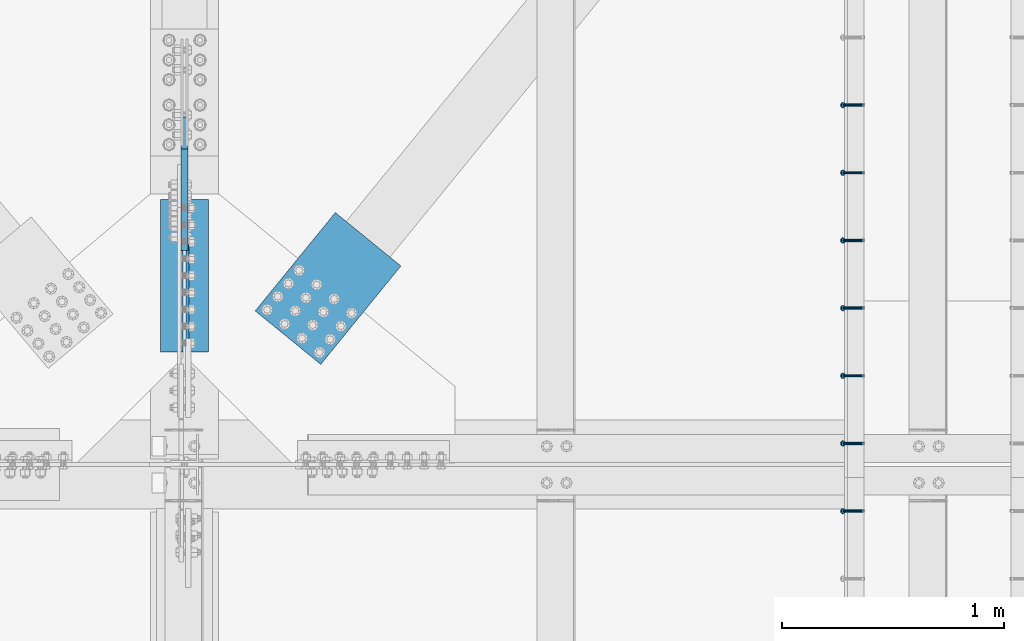
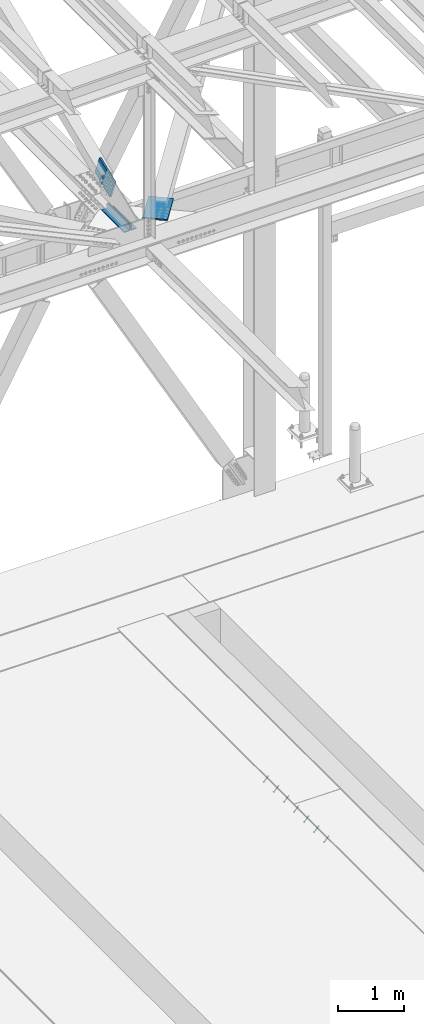
# One storey, part 2493 of 3843: 8 members, 3 beams, 6 elements without a shape of their own.
"""IFC2X3 building model written with IfcOpenShell, lengths in millimetres."""

from ifc_helpers import new_model, si_unit, frame, origin_with_axes, place, context, subcontext, project, spatial, faceted_brep, material, type_object, element, aggregate, save


model = new_model("IFC2X3")

# Units and contexts
model_context = context("Model", 3, precision=1e-05, world=origin_with_axes())
body_context = subcontext(model_context, "Body", "Model", "MODEL_VIEW")
ifc_project = project(units=[si_unit("LENGTHUNIT", "METRE", prefix="MILLI"), si_unit("AREAUNIT", "SQUARE_METRE"), si_unit("VOLUMEUNIT", "CUBIC_METRE"), si_unit("MASSUNIT", "GRAM", prefix="KILO"), si_unit("TIMEUNIT", "SECOND"), si_unit("PLANEANGLEUNIT", "RADIAN"), si_unit("SOLIDANGLEUNIT", "STERADIAN"), si_unit("THERMODYNAMICTEMPERATUREUNIT", "DEGREE_CELSIUS"), si_unit("LUMINOUSINTENSITYUNIT", "LUMEN")], contexts=[model_context])

# Site, building, storey
site_placement = place(None, origin_with_axes())
site = spatial("IfcSite", under=ifc_project, at=site_placement, CompositionType="ELEMENT")
building_placement = place(site_placement, origin_with_axes())
building = spatial("IfcBuilding", under=site, at=building_placement, Name="Undefined", CompositionType="ELEMENT")
storey_placement = place(building_placement, origin_with_axes())
storey = spatial("IfcBuildingStorey", under=building, at=storey_placement, Name="Undefined", CompositionType="ELEMENT", Elevation=0.0)

# Assembly, member
assembly_1_placement = place(storey_placement, origin_with_axes())
assembly_1 = element("IfcElementAssembly", 1, at=assembly_1_placement, inside=storey, Name="EMBED_ANGLE", AssemblyPlace="NOTDEFINED", PredefinedType="RIGID_FRAME")
ifc_material_1 = material(Name="STEEL/A108")
member_type_1 = type_object("IfcMemberType", PredefinedType="NOTDEFINED")
member_1_placement = place(assembly_1_placement, frame((58984.3878603516, 83775.4223186035, 30446.6625), z_axis=(0.0, 1.0, 0.0), x_axis=(-0.707106781186548, 0.0, -0.707106781186548)))
member_1 = element("IfcMember", 2, at=member_1_placement, type_object=member_type_1, material=ifc_material_1, Name="HEADED STUD ANCHOR", context=body_context, shape_type="Brep", body=[
    faceted_brep([(7.27595761418343e-12, -3.18000006675175, 5.5), (0.0, -5.49999999998363, 3.1800000667572), (118.110000000976, -5.49999999999091, 3.1800000667572), (118.110000000983, -3.18000006675175, 5.5), (0.0, -6.3499999046162, 0.0), (118.110000000968, -6.34999990461256, 0.0), (0.0, -5.49999999998363, -3.1800000667572), (118.110000000976, -5.49999999999091, -3.1800000667572), (7.27595761418343e-12, -3.18000006675175, -5.5), (118.110000000983, -3.18000006675175, -5.5), (7.27595761418343e-12, -1.81898940354586e-12, -6.34999990463257), (118.110000000968, -1.81898940354586e-12, -6.34999990463257), (0.0, 3.18000006675175, -5.5), (118.110000000968, 3.18000006674811, -5.5), (7.27595761418343e-12, 5.49999999998363, -3.1800000667572), (118.110000000983, 5.49999999998363, -3.1800000667572), (7.27595761418343e-12, 6.3499999046162, 0.0), (118.110000000976, 6.34999990461256, 0.0), (7.27595761418343e-12, 5.49999999998363, 3.1800000667572), (118.110000000983, 5.49999999998363, 3.1800000667572), (0.0, 3.18000006675175, 5.5), (118.110000000968, 3.18000006674811, 5.5), (7.27595761418343e-12, -1.81898940354586e-12, 6.34999990463257), (118.110000000968, -1.81898940354586e-12, 6.34999990463257), (120.650000000991, -10.9899997710909, 6.34999990463257), (120.650000000998, -6.34000015257152, 10.9899997711182), (120.650000000991, -12.6999998092379, 0.0), (120.650000000991, -10.9899997710909, -6.34999990463257), (120.650000000998, -6.34000015257152, -10.9899997711182), (120.650000000991, -1.81898940354586e-12, -12.6899995803833), (120.650000000991, 6.34000015257152, -10.9899997711182), (120.650000000998, 10.9899997710909, -6.34999990463257), (120.650000000991, 12.6999998092342, 0.0), (120.650000000998, 10.9899997710909, 6.34999990463257), (120.650000000991, 6.34000015257152, 10.9899997711182), (120.650000000991, -1.81898940354586e-12, 12.6899995803833), (127.000000001048, -10.9899997710945, 6.34999990463257), (127.000000001048, -6.34000015257152, 10.9899997711182), (127.000000001048, -12.6999998092342, 0.0), (127.000000001048, -10.9899997710945, -6.34999990463257), (127.000000001048, -6.34000015257152, -10.9899997711182), (127.000000001048, 1.81898940354586e-12, -12.6899995803833), (127.000000001048, 6.34000015256788, -10.9899997711182), (127.000000001048, 10.9899997710909, -6.34999990463257), (127.000000001048, 12.6999998092379, 0.0), (127.000000001048, 10.9899997710909, 6.34999990463257), (127.000000001048, 6.34000015256788, 10.9899997711182), (127.000000001048, 1.81898940354586e-12, 12.6899995803833)], [[[0, 1, 2, 3]], [[1, 4, 5, 2]], [[4, 6, 7, 5]], [[6, 8, 9, 7]], [[8, 10, 11, 9]], [[10, 12, 13, 11]], [[12, 14, 15, 13]], [[14, 16, 17, 15]], [[16, 18, 19, 17]], [[18, 20, 21, 19]], [[20, 22, 23, 21]], [[22, 0, 3, 23]], [[22, 20, 18, 16, 14, 12, 10, 8, 6, 4, 1, 0]], [[3, 2, 24, 25]], [[2, 5, 26, 24]], [[5, 7, 27, 26]], [[7, 9, 28, 27]], [[9, 11, 29, 28]], [[11, 13, 30, 29]], [[13, 15, 31, 30]], [[15, 17, 32, 31]], [[17, 19, 33, 32]], [[19, 21, 34, 33]], [[21, 23, 35, 34]], [[23, 3, 25, 35]], [[25, 24, 36, 37]], [[24, 26, 38, 36]], [[26, 27, 39, 38]], [[27, 28, 40, 39]], [[28, 29, 41, 40]], [[29, 30, 42, 41]], [[30, 31, 43, 42]], [[31, 32, 44, 43]], [[32, 33, 45, 44]], [[33, 34, 46, 45]], [[34, 35, 47, 46]], [[35, 25, 37, 47]], [[38, 39, 40, 41, 42, 43, 44, 45, 46, 47, 37, 36]]]),
])
aggregate(assembly_1, [member_1])

# Assembly, members
assembly_2_placement = place(storey_placement, origin_with_axes())
assembly_2 = element("IfcElementAssembly", 3, at=assembly_2_placement, inside=storey, Name="EMBED_ANGLE", AssemblyPlace="NOTDEFINED", PredefinedType="RIGID_FRAME")
member_2_placement = place(assembly_2_placement, frame((58984.3878603516, 84080.2223186035, 30446.6625), z_axis=(0.0, 1.0, 0.0), x_axis=(-0.707106781186548, 0.0, -0.707106781186548)))
member_2 = element("IfcMember", 4, at=member_2_placement, type_object=member_type_1, material=ifc_material_1, Name="HEADED STUD ANCHOR", context=body_context, shape_type="Brep", body=[
    faceted_brep([(7.27595761418343e-12, -3.18000006675175, 5.5), (0.0, -5.49999999998363, 3.1800000667572), (118.110000000976, -5.49999999999091, 3.1800000667572), (118.110000000983, -3.18000006675175, 5.5), (0.0, -6.3499999046162, 0.0), (118.110000000968, -6.34999990461256, 0.0), (0.0, -5.49999999998363, -3.1800000667572), (118.110000000976, -5.49999999999091, -3.1800000667572), (7.27595761418343e-12, -3.18000006675175, -5.5), (118.110000000983, -3.18000006675175, -5.5), (7.27595761418343e-12, -1.81898940354586e-12, -6.34999990463257), (118.110000000968, -1.81898940354586e-12, -6.34999990463257), (0.0, 3.18000006675175, -5.5), (118.110000000968, 3.18000006674811, -5.5), (7.27595761418343e-12, 5.49999999998363, -3.1800000667572), (118.110000000983, 5.49999999998363, -3.1800000667572), (7.27595761418343e-12, 6.3499999046162, 0.0), (118.110000000976, 6.34999990461256, 0.0), (7.27595761418343e-12, 5.49999999998363, 3.1800000667572), (118.110000000983, 5.49999999998363, 3.1800000667572), (0.0, 3.18000006675175, 5.5), (118.110000000968, 3.18000006674811, 5.5), (7.27595761418343e-12, -1.81898940354586e-12, 6.34999990463257), (118.110000000968, -1.81898940354586e-12, 6.34999990463257), (120.650000000991, -10.9899997710909, 6.34999990463257), (120.650000000998, -6.34000015257152, 10.9899997711182), (120.650000000991, -12.6999998092379, 0.0), (120.650000000991, -10.9899997710909, -6.34999990463257), (120.650000000998, -6.34000015257152, -10.9899997711182), (120.650000000991, -1.81898940354586e-12, -12.6899995803833), (120.650000000991, 6.34000015257152, -10.9899997711182), (120.650000000998, 10.9899997710909, -6.34999990463257), (120.650000000991, 12.6999998092342, 0.0), (120.650000000998, 10.9899997710909, 6.34999990463257), (120.650000000991, 6.34000015257152, 10.9899997711182), (120.650000000991, -1.81898940354586e-12, 12.6899995803833), (127.000000001048, -10.9899997710945, 6.34999990463257), (127.000000001048, -6.34000015257152, 10.9899997711182), (127.000000001048, -12.6999998092342, 0.0), (127.000000001048, -10.9899997710945, -6.34999990463257), (127.000000001048, -6.34000015257152, -10.9899997711182), (127.000000001048, 1.81898940354586e-12, -12.6899995803833), (127.000000001048, 6.34000015256788, -10.9899997711182), (127.000000001048, 10.9899997710909, -6.34999990463257), (127.000000001048, 12.6999998092379, 0.0), (127.000000001048, 10.9899997710909, 6.34999990463257), (127.000000001048, 6.34000015256788, 10.9899997711182), (127.000000001048, 1.81898940354586e-12, 12.6899995803833)], [[[0, 1, 2, 3]], [[1, 4, 5, 2]], [[4, 6, 7, 5]], [[6, 8, 9, 7]], [[8, 10, 11, 9]], [[10, 12, 13, 11]], [[12, 14, 15, 13]], [[14, 16, 17, 15]], [[16, 18, 19, 17]], [[18, 20, 21, 19]], [[20, 22, 23, 21]], [[22, 0, 3, 23]], [[22, 20, 18, 16, 14, 12, 10, 8, 6, 4, 1, 0]], [[3, 2, 24, 25]], [[2, 5, 26, 24]], [[5, 7, 27, 26]], [[7, 9, 28, 27]], [[9, 11, 29, 28]], [[11, 13, 30, 29]], [[13, 15, 31, 30]], [[15, 17, 32, 31]], [[17, 19, 33, 32]], [[19, 21, 34, 33]], [[21, 23, 35, 34]], [[23, 3, 25, 35]], [[25, 24, 36, 37]], [[24, 26, 38, 36]], [[26, 27, 39, 38]], [[27, 28, 40, 39]], [[28, 29, 41, 40]], [[29, 30, 42, 41]], [[30, 31, 43, 42]], [[31, 32, 44, 43]], [[32, 33, 45, 44]], [[33, 34, 46, 45]], [[34, 35, 47, 46]], [[35, 25, 37, 47]], [[38, 39, 40, 41, 42, 43, 44, 45, 46, 47, 37, 36]]]),
])
member_3_placement = place(assembly_2_placement, frame((58984.3878603516, 84385.0223186035, 30446.6625), z_axis=(0.0, 1.0, 0.0), x_axis=(-0.707106781186548, 0.0, -0.707106781186548)))
member_3 = element("IfcMember", 5, at=member_3_placement, type_object=member_type_1, material=ifc_material_1, Name="HEADED STUD ANCHOR", context=body_context, shape_type="Brep", body=[
    faceted_brep([(7.27595761418343e-12, -3.18000006675175, 5.5), (0.0, -5.49999999998363, 3.1800000667572), (118.110000000976, -5.49999999999091, 3.1800000667572), (118.110000000983, -3.18000006675175, 5.5), (0.0, -6.3499999046162, 0.0), (118.110000000968, -6.34999990461256, 0.0), (0.0, -5.49999999998363, -3.1800000667572), (118.110000000976, -5.49999999999091, -3.1800000667572), (7.27595761418343e-12, -3.18000006675175, -5.5), (118.110000000983, -3.18000006675175, -5.5), (7.27595761418343e-12, -1.81898940354586e-12, -6.34999990463257), (118.110000000968, -1.81898940354586e-12, -6.34999990463257), (0.0, 3.18000006675175, -5.5), (118.110000000968, 3.18000006674811, -5.5), (7.27595761418343e-12, 5.49999999998363, -3.1800000667572), (118.110000000983, 5.49999999998363, -3.1800000667572), (7.27595761418343e-12, 6.3499999046162, 0.0), (118.110000000976, 6.34999990461256, 0.0), (7.27595761418343e-12, 5.49999999998363, 3.1800000667572), (118.110000000983, 5.49999999998363, 3.1800000667572), (0.0, 3.18000006675175, 5.5), (118.110000000968, 3.18000006674811, 5.5), (7.27595761418343e-12, -1.81898940354586e-12, 6.34999990463257), (118.110000000968, -1.81898940354586e-12, 6.34999990463257), (120.650000000991, -10.9899997710909, 6.34999990463257), (120.650000000998, -6.34000015257152, 10.9899997711182), (120.650000000991, -12.6999998092379, 0.0), (120.650000000991, -10.9899997710909, -6.34999990463257), (120.650000000998, -6.34000015257152, -10.9899997711182), (120.650000000991, -1.81898940354586e-12, -12.6899995803833), (120.650000000991, 6.34000015257152, -10.9899997711182), (120.650000000998, 10.9899997710909, -6.34999990463257), (120.650000000991, 12.6999998092342, 0.0), (120.650000000998, 10.9899997710909, 6.34999990463257), (120.650000000991, 6.34000015257152, 10.9899997711182), (120.650000000991, -1.81898940354586e-12, 12.6899995803833), (127.000000001048, -10.9899997710945, 6.34999990463257), (127.000000001048, -6.34000015257152, 10.9899997711182), (127.000000001048, -12.6999998092342, 0.0), (127.000000001048, -10.9899997710945, -6.34999990463257), (127.000000001048, -6.34000015257152, -10.9899997711182), (127.000000001048, 1.81898940354586e-12, -12.6899995803833), (127.000000001048, 6.34000015256788, -10.9899997711182), (127.000000001048, 10.9899997710909, -6.34999990463257), (127.000000001048, 12.6999998092379, 0.0), (127.000000001048, 10.9899997710909, 6.34999990463257), (127.000000001048, 6.34000015256788, 10.9899997711182), (127.000000001048, 1.81898940354586e-12, 12.6899995803833)], [[[0, 1, 2, 3]], [[1, 4, 5, 2]], [[4, 6, 7, 5]], [[6, 8, 9, 7]], [[8, 10, 11, 9]], [[10, 12, 13, 11]], [[12, 14, 15, 13]], [[14, 16, 17, 15]], [[16, 18, 19, 17]], [[18, 20, 21, 19]], [[20, 22, 23, 21]], [[22, 0, 3, 23]], [[22, 20, 18, 16, 14, 12, 10, 8, 6, 4, 1, 0]], [[3, 2, 24, 25]], [[2, 5, 26, 24]], [[5, 7, 27, 26]], [[7, 9, 28, 27]], [[9, 11, 29, 28]], [[11, 13, 30, 29]], [[13, 15, 31, 30]], [[15, 17, 32, 31]], [[17, 19, 33, 32]], [[19, 21, 34, 33]], [[21, 23, 35, 34]], [[23, 3, 25, 35]], [[25, 24, 36, 37]], [[24, 26, 38, 36]], [[26, 27, 39, 38]], [[27, 28, 40, 39]], [[28, 29, 41, 40]], [[29, 30, 42, 41]], [[30, 31, 43, 42]], [[31, 32, 44, 43]], [[32, 33, 45, 44]], [[33, 34, 46, 45]], [[34, 35, 47, 46]], [[35, 25, 37, 47]], [[38, 39, 40, 41, 42, 43, 44, 45, 46, 47, 37, 36]]]),
])
member_4_placement = place(assembly_2_placement, frame((58984.3878603516, 84689.8223186035, 30446.6625), z_axis=(0.0, 1.0, 0.0), x_axis=(-0.707106781186548, 0.0, -0.707106781186548)))
member_4 = element("IfcMember", 6, at=member_4_placement, type_object=member_type_1, material=ifc_material_1, Name="HEADED STUD ANCHOR", context=body_context, shape_type="Brep", body=[
    faceted_brep([(7.27595761418343e-12, -3.18000006675175, 5.5), (0.0, -5.49999999998363, 3.1800000667572), (118.110000000976, -5.49999999999091, 3.1800000667572), (118.110000000983, -3.18000006675175, 5.5), (0.0, -6.3499999046162, 0.0), (118.110000000968, -6.34999990461256, 0.0), (0.0, -5.49999999998363, -3.1800000667572), (118.110000000976, -5.49999999999091, -3.1800000667572), (7.27595761418343e-12, -3.18000006675175, -5.5), (118.110000000983, -3.18000006675175, -5.5), (7.27595761418343e-12, -1.81898940354586e-12, -6.34999990463257), (118.110000000968, -1.81898940354586e-12, -6.34999990463257), (0.0, 3.18000006675175, -5.5), (118.110000000968, 3.18000006674811, -5.5), (7.27595761418343e-12, 5.49999999998363, -3.1800000667572), (118.110000000983, 5.49999999998363, -3.1800000667572), (7.27595761418343e-12, 6.3499999046162, 0.0), (118.110000000976, 6.34999990461256, 0.0), (7.27595761418343e-12, 5.49999999998363, 3.1800000667572), (118.110000000983, 5.49999999998363, 3.1800000667572), (0.0, 3.18000006675175, 5.5), (118.110000000968, 3.18000006674811, 5.5), (7.27595761418343e-12, -1.81898940354586e-12, 6.34999990463257), (118.110000000968, -1.81898940354586e-12, 6.34999990463257), (120.650000000991, -10.9899997710909, 6.34999990463257), (120.650000000998, -6.34000015257152, 10.9899997711182), (120.650000000991, -12.6999998092379, 0.0), (120.650000000991, -10.9899997710909, -6.34999990463257), (120.650000000998, -6.34000015257152, -10.9899997711182), (120.650000000991, -1.81898940354586e-12, -12.6899995803833), (120.650000000991, 6.34000015257152, -10.9899997711182), (120.650000000998, 10.9899997710909, -6.34999990463257), (120.650000000991, 12.6999998092342, 0.0), (120.650000000998, 10.9899997710909, 6.34999990463257), (120.650000000991, 6.34000015257152, 10.9899997711182), (120.650000000991, -1.81898940354586e-12, 12.6899995803833), (127.000000001048, -10.9899997710945, 6.34999990463257), (127.000000001048, -6.34000015257152, 10.9899997711182), (127.000000001048, -12.6999998092342, 0.0), (127.000000001048, -10.9899997710945, -6.34999990463257), (127.000000001048, -6.34000015257152, -10.9899997711182), (127.000000001048, 1.81898940354586e-12, -12.6899995803833), (127.000000001048, 6.34000015256788, -10.9899997711182), (127.000000001048, 10.9899997710909, -6.34999990463257), (127.000000001048, 12.6999998092379, 0.0), (127.000000001048, 10.9899997710909, 6.34999990463257), (127.000000001048, 6.34000015256788, 10.9899997711182), (127.000000001048, 1.81898940354586e-12, 12.6899995803833)], [[[0, 1, 2, 3]], [[1, 4, 5, 2]], [[4, 6, 7, 5]], [[6, 8, 9, 7]], [[8, 10, 11, 9]], [[10, 12, 13, 11]], [[12, 14, 15, 13]], [[14, 16, 17, 15]], [[16, 18, 19, 17]], [[18, 20, 21, 19]], [[20, 22, 23, 21]], [[22, 0, 3, 23]], [[22, 20, 18, 16, 14, 12, 10, 8, 6, 4, 1, 0]], [[3, 2, 24, 25]], [[2, 5, 26, 24]], [[5, 7, 27, 26]], [[7, 9, 28, 27]], [[9, 11, 29, 28]], [[11, 13, 30, 29]], [[13, 15, 31, 30]], [[15, 17, 32, 31]], [[17, 19, 33, 32]], [[19, 21, 34, 33]], [[21, 23, 35, 34]], [[23, 3, 25, 35]], [[25, 24, 36, 37]], [[24, 26, 38, 36]], [[26, 27, 39, 38]], [[27, 28, 40, 39]], [[28, 29, 41, 40]], [[29, 30, 42, 41]], [[30, 31, 43, 42]], [[31, 32, 44, 43]], [[32, 33, 45, 44]], [[33, 34, 46, 45]], [[34, 35, 47, 46]], [[35, 25, 37, 47]], [[38, 39, 40, 41, 42, 43, 44, 45, 46, 47, 37, 36]]]),
])
member_5_placement = place(assembly_2_placement, frame((58984.3878603516, 84994.6223186035, 30446.6625), z_axis=(0.0, 1.0, 0.0), x_axis=(-0.707106781186548, 0.0, -0.707106781186548)))
member_5 = element("IfcMember", 7, at=member_5_placement, type_object=member_type_1, material=ifc_material_1, Name="HEADED STUD ANCHOR", context=body_context, shape_type="Brep", body=[
    faceted_brep([(7.27595761418343e-12, -3.18000006675175, 5.5), (0.0, -5.49999999998363, 3.1800000667572), (118.110000000976, -5.49999999999091, 3.1800000667572), (118.110000000983, -3.18000006675175, 5.5), (0.0, -6.3499999046162, 0.0), (118.110000000968, -6.34999990461256, 0.0), (0.0, -5.49999999998363, -3.1800000667572), (118.110000000976, -5.49999999999091, -3.1800000667572), (7.27595761418343e-12, -3.18000006675175, -5.5), (118.110000000983, -3.18000006675175, -5.5), (7.27595761418343e-12, -1.81898940354586e-12, -6.34999990463257), (118.110000000968, -1.81898940354586e-12, -6.34999990463257), (0.0, 3.18000006675175, -5.5), (118.110000000968, 3.18000006674811, -5.5), (7.27595761418343e-12, 5.49999999998363, -3.1800000667572), (118.110000000983, 5.49999999998363, -3.1800000667572), (7.27595761418343e-12, 6.3499999046162, 0.0), (118.110000000976, 6.34999990461256, 0.0), (7.27595761418343e-12, 5.49999999998363, 3.1800000667572), (118.110000000983, 5.49999999998363, 3.1800000667572), (0.0, 3.18000006675175, 5.5), (118.110000000968, 3.18000006674811, 5.5), (7.27595761418343e-12, -1.81898940354586e-12, 6.34999990463257), (118.110000000968, -1.81898940354586e-12, 6.34999990463257), (120.650000000991, -10.9899997710909, 6.34999990463257), (120.650000000998, -6.34000015257152, 10.9899997711182), (120.650000000991, -12.6999998092379, 0.0), (120.650000000991, -10.9899997710909, -6.34999990463257), (120.650000000998, -6.34000015257152, -10.9899997711182), (120.650000000991, -1.81898940354586e-12, -12.6899995803833), (120.650000000991, 6.34000015257152, -10.9899997711182), (120.650000000998, 10.9899997710909, -6.34999990463257), (120.650000000991, 12.6999998092342, 0.0), (120.650000000998, 10.9899997710909, 6.34999990463257), (120.650000000991, 6.34000015257152, 10.9899997711182), (120.650000000991, -1.81898940354586e-12, 12.6899995803833), (127.000000001048, -10.9899997710945, 6.34999990463257), (127.000000001048, -6.34000015257152, 10.9899997711182), (127.000000001048, -12.6999998092342, 0.0), (127.000000001048, -10.9899997710945, -6.34999990463257), (127.000000001048, -6.34000015257152, -10.9899997711182), (127.000000001048, 1.81898940354586e-12, -12.6899995803833), (127.000000001048, 6.34000015256788, -10.9899997711182), (127.000000001048, 10.9899997710909, -6.34999990463257), (127.000000001048, 12.6999998092379, 0.0), (127.000000001048, 10.9899997710909, 6.34999990463257), (127.000000001048, 6.34000015256788, 10.9899997711182), (127.000000001048, 1.81898940354586e-12, 12.6899995803833)], [[[0, 1, 2, 3]], [[1, 4, 5, 2]], [[4, 6, 7, 5]], [[6, 8, 9, 7]], [[8, 10, 11, 9]], [[10, 12, 13, 11]], [[12, 14, 15, 13]], [[14, 16, 17, 15]], [[16, 18, 19, 17]], [[18, 20, 21, 19]], [[20, 22, 23, 21]], [[22, 0, 3, 23]], [[22, 20, 18, 16, 14, 12, 10, 8, 6, 4, 1, 0]], [[3, 2, 24, 25]], [[2, 5, 26, 24]], [[5, 7, 27, 26]], [[7, 9, 28, 27]], [[9, 11, 29, 28]], [[11, 13, 30, 29]], [[13, 15, 31, 30]], [[15, 17, 32, 31]], [[17, 19, 33, 32]], [[19, 21, 34, 33]], [[21, 23, 35, 34]], [[23, 3, 25, 35]], [[25, 24, 36, 37]], [[24, 26, 38, 36]], [[26, 27, 39, 38]], [[27, 28, 40, 39]], [[28, 29, 41, 40]], [[29, 30, 42, 41]], [[30, 31, 43, 42]], [[31, 32, 44, 43]], [[32, 33, 45, 44]], [[33, 34, 46, 45]], [[34, 35, 47, 46]], [[35, 25, 37, 47]], [[38, 39, 40, 41, 42, 43, 44, 45, 46, 47, 37, 36]]]),
])
member_6_placement = place(assembly_2_placement, frame((58984.3878603516, 85299.4223186035, 30446.6625), z_axis=(0.0, 1.0, 0.0), x_axis=(-0.707106781186548, 0.0, -0.707106781186548)))
member_6 = element("IfcMember", 8, at=member_6_placement, type_object=member_type_1, material=ifc_material_1, Name="HEADED STUD ANCHOR", context=body_context, shape_type="Brep", body=[
    faceted_brep([(7.27595761418343e-12, -3.18000006675175, 5.5), (0.0, -5.49999999998363, 3.1800000667572), (118.110000000976, -5.49999999999091, 3.1800000667572), (118.110000000983, -3.18000006675175, 5.5), (0.0, -6.3499999046162, 0.0), (118.110000000968, -6.34999990461256, 0.0), (0.0, -5.49999999998363, -3.1800000667572), (118.110000000976, -5.49999999999091, -3.1800000667572), (7.27595761418343e-12, -3.18000006675175, -5.5), (118.110000000983, -3.18000006675175, -5.5), (7.27595761418343e-12, -1.81898940354586e-12, -6.34999990463257), (118.110000000968, -1.81898940354586e-12, -6.34999990463257), (0.0, 3.18000006675175, -5.5), (118.110000000968, 3.18000006674811, -5.5), (7.27595761418343e-12, 5.49999999998363, -3.1800000667572), (118.110000000983, 5.49999999998363, -3.1800000667572), (7.27595761418343e-12, 6.3499999046162, 0.0), (118.110000000976, 6.34999990461256, 0.0), (7.27595761418343e-12, 5.49999999998363, 3.1800000667572), (118.110000000983, 5.49999999998363, 3.1800000667572), (0.0, 3.18000006675175, 5.5), (118.110000000968, 3.18000006674811, 5.5), (7.27595761418343e-12, -1.81898940354586e-12, 6.34999990463257), (118.110000000968, -1.81898940354586e-12, 6.34999990463257), (120.650000000991, -10.9899997710909, 6.34999990463257), (120.650000000998, -6.34000015257152, 10.9899997711182), (120.650000000991, -12.6999998092379, 0.0), (120.650000000991, -10.9899997710909, -6.34999990463257), (120.650000000998, -6.34000015257152, -10.9899997711182), (120.650000000991, -1.81898940354586e-12, -12.6899995803833), (120.650000000991, 6.34000015257152, -10.9899997711182), (120.650000000998, 10.9899997710909, -6.34999990463257), (120.650000000991, 12.6999998092342, 0.0), (120.650000000998, 10.9899997710909, 6.34999990463257), (120.650000000991, 6.34000015257152, 10.9899997711182), (120.650000000991, -1.81898940354586e-12, 12.6899995803833), (127.000000001048, -10.9899997710945, 6.34999990463257), (127.000000001048, -6.34000015257152, 10.9899997711182), (127.000000001048, -12.6999998092342, 0.0), (127.000000001048, -10.9899997710945, -6.34999990463257), (127.000000001048, -6.34000015257152, -10.9899997711182), (127.000000001048, 1.81898940354586e-12, -12.6899995803833), (127.000000001048, 6.34000015256788, -10.9899997711182), (127.000000001048, 10.9899997710909, -6.34999990463257), (127.000000001048, 12.6999998092379, 0.0), (127.000000001048, 10.9899997710909, 6.34999990463257), (127.000000001048, 6.34000015256788, 10.9899997711182), (127.000000001048, 1.81898940354586e-12, 12.6899995803833)], [[[0, 1, 2, 3]], [[1, 4, 5, 2]], [[4, 6, 7, 5]], [[6, 8, 9, 7]], [[8, 10, 11, 9]], [[10, 12, 13, 11]], [[12, 14, 15, 13]], [[14, 16, 17, 15]], [[16, 18, 19, 17]], [[18, 20, 21, 19]], [[20, 22, 23, 21]], [[22, 0, 3, 23]], [[22, 20, 18, 16, 14, 12, 10, 8, 6, 4, 1, 0]], [[3, 2, 24, 25]], [[2, 5, 26, 24]], [[5, 7, 27, 26]], [[7, 9, 28, 27]], [[9, 11, 29, 28]], [[11, 13, 30, 29]], [[13, 15, 31, 30]], [[15, 17, 32, 31]], [[17, 19, 33, 32]], [[19, 21, 34, 33]], [[21, 23, 35, 34]], [[23, 3, 25, 35]], [[25, 24, 36, 37]], [[24, 26, 38, 36]], [[26, 27, 39, 38]], [[27, 28, 40, 39]], [[28, 29, 41, 40]], [[29, 30, 42, 41]], [[30, 31, 43, 42]], [[31, 32, 44, 43]], [[32, 33, 45, 44]], [[33, 34, 46, 45]], [[34, 35, 47, 46]], [[35, 25, 37, 47]], [[38, 39, 40, 41, 42, 43, 44, 45, 46, 47, 37, 36]]]),
])
member_7_placement = place(assembly_2_placement, frame((58984.3878603516, 85604.2223186035, 30446.6625), z_axis=(0.0, 1.0, 0.0), x_axis=(-0.707106781186548, 0.0, -0.707106781186548)))
member_7 = element("IfcMember", 9, at=member_7_placement, type_object=member_type_1, material=ifc_material_1, Name="HEADED STUD ANCHOR", context=body_context, shape_type="Brep", body=[
    faceted_brep([(7.27595761418343e-12, -3.18000006675175, 5.5), (0.0, -5.49999999998363, 3.1800000667572), (118.110000000976, -5.49999999999091, 3.1800000667572), (118.110000000983, -3.18000006675175, 5.5), (0.0, -6.3499999046162, 0.0), (118.110000000968, -6.34999990461256, 0.0), (0.0, -5.49999999998363, -3.1800000667572), (118.110000000976, -5.49999999999091, -3.1800000667572), (7.27595761418343e-12, -3.18000006675175, -5.5), (118.110000000983, -3.18000006675175, -5.5), (7.27595761418343e-12, -1.81898940354586e-12, -6.34999990463257), (118.110000000968, -1.81898940354586e-12, -6.34999990463257), (0.0, 3.18000006675175, -5.5), (118.110000000968, 3.18000006674811, -5.5), (7.27595761418343e-12, 5.49999999998363, -3.1800000667572), (118.110000000983, 5.49999999998363, -3.1800000667572), (7.27595761418343e-12, 6.3499999046162, 0.0), (118.110000000976, 6.34999990461256, 0.0), (7.27595761418343e-12, 5.49999999998363, 3.1800000667572), (118.110000000983, 5.49999999998363, 3.1800000667572), (0.0, 3.18000006675175, 5.5), (118.110000000968, 3.18000006674811, 5.5), (7.27595761418343e-12, -1.81898940354586e-12, 6.34999990463257), (118.110000000968, -1.81898940354586e-12, 6.34999990463257), (120.650000000991, -10.9899997710909, 6.34999990463257), (120.650000000998, -6.34000015257152, 10.9899997711182), (120.650000000991, -12.6999998092379, 0.0), (120.650000000991, -10.9899997710909, -6.34999990463257), (120.650000000998, -6.34000015257152, -10.9899997711182), (120.650000000991, -1.81898940354586e-12, -12.6899995803833), (120.650000000991, 6.34000015257152, -10.9899997711182), (120.650000000998, 10.9899997710909, -6.34999990463257), (120.650000000991, 12.6999998092342, 0.0), (120.650000000998, 10.9899997710909, 6.34999990463257), (120.650000000991, 6.34000015257152, 10.9899997711182), (120.650000000991, -1.81898940354586e-12, 12.6899995803833), (127.000000001048, -10.9899997710945, 6.34999990463257), (127.000000001048, -6.34000015257152, 10.9899997711182), (127.000000001048, -12.6999998092342, 0.0), (127.000000001048, -10.9899997710945, -6.34999990463257), (127.000000001048, -6.34000015257152, -10.9899997711182), (127.000000001048, 1.81898940354586e-12, -12.6899995803833), (127.000000001048, 6.34000015256788, -10.9899997711182), (127.000000001048, 10.9899997710909, -6.34999990463257), (127.000000001048, 12.6999998092379, 0.0), (127.000000001048, 10.9899997710909, 6.34999990463257), (127.000000001048, 6.34000015256788, 10.9899997711182), (127.000000001048, 1.81898940354586e-12, 12.6899995803833)], [[[0, 1, 2, 3]], [[1, 4, 5, 2]], [[4, 6, 7, 5]], [[6, 8, 9, 7]], [[8, 10, 11, 9]], [[10, 12, 13, 11]], [[12, 14, 15, 13]], [[14, 16, 17, 15]], [[16, 18, 19, 17]], [[18, 20, 21, 19]], [[20, 22, 23, 21]], [[22, 0, 3, 23]], [[22, 20, 18, 16, 14, 12, 10, 8, 6, 4, 1, 0]], [[3, 2, 24, 25]], [[2, 5, 26, 24]], [[5, 7, 27, 26]], [[7, 9, 28, 27]], [[9, 11, 29, 28]], [[11, 13, 30, 29]], [[13, 15, 31, 30]], [[15, 17, 32, 31]], [[17, 19, 33, 32]], [[19, 21, 34, 33]], [[21, 23, 35, 34]], [[23, 3, 25, 35]], [[25, 24, 36, 37]], [[24, 26, 38, 36]], [[26, 27, 39, 38]], [[27, 28, 40, 39]], [[28, 29, 41, 40]], [[29, 30, 42, 41]], [[30, 31, 43, 42]], [[31, 32, 44, 43]], [[32, 33, 45, 44]], [[33, 34, 46, 45]], [[34, 35, 47, 46]], [[35, 25, 37, 47]], [[38, 39, 40, 41, 42, 43, 44, 45, 46, 47, 37, 36]]]),
])
aggregate(assembly_2, [member_2, member_3, member_4, member_5, member_6, member_7])

# Assembly, beam
assembly_3_placement = place(storey_placement, origin_with_axes())
assembly_3 = element("IfcElementAssembly", 10, at=assembly_3_placement, inside=storey, Name="PLATE", AssemblyPlace="NOTDEFINED", PredefinedType="RIGID_FRAME")
ifc_material_2 = material(Name="STEEL/A572-50")
beam_type_1 = type_object("IfcBeamType", Name="L4X4X1/2", PredefinedType="NOTDEFINED")
beam_1_placement = place(assembly_3_placement, frame((55987.9499999819, 85178.8999999994, 42297.3493367002), z_axis=(1.0, 0.0, 0.0), x_axis=(0.0, -1.0, 0.0)))
beam_1 = element("IfcBeam", 11, at=beam_1_placement, type_object=beam_type_1, material=ifc_material_2, Name="ANGLE", ObjectType="L4X4X1/2", context=body_context, shape_type="Brep", body=[
    faceted_brep([(0.0, 50.8000000000029, -50.8000000000029), (0.0, 50.8000000000029, 50.8000000000029), (685.800000000003, 50.8000000000029, 50.8000000000029), (685.800000000003, 50.8000000000029, -50.8000000000029), (0.0, 38.0999999999985, 50.8000000000029), (685.800000000003, 38.0999999999985, 50.8000000000029), (0.0, 38.0999999999985, -38.0999999999985), (685.800000000003, 38.0999999999985, -38.1000000000058), (0.0, -50.8000000000029, -38.1000000000058), (685.800000000003, -50.8000000000029, -38.1000000000058), (0.0, -50.8000000000029, -50.8000000000029), (685.800000000003, -50.8000000000029, -50.8000000000029)], [[[0, 1, 2, 3]], [[1, 4, 5, 2]], [[4, 6, 7, 5]], [[6, 8, 9, 7]], [[8, 10, 11, 9]], [[10, 0, 3, 11]], [[5, 7, 9, 11, 3, 2]], [[10, 8, 6, 4, 1, 0]]]),
])
aggregate(assembly_3, [beam_1])

assembly_4_placement = place(storey_placement, origin_with_axes())
assembly_4 = element("IfcElementAssembly", 12, at=assembly_4_placement, inside=storey, Name="PLATE", AssemblyPlace="NOTDEFINED", PredefinedType="RIGID_FRAME")
beam_2_placement = place(assembly_4_placement, frame((55873.6499999748, 84493.1000000014, 42297.3503366567), z_axis=(-1.0, 0.0, 0.0), x_axis=(0.0, 1.0, 0.0)))
beam_2 = element("IfcBeam", 13, at=beam_2_placement, type_object=beam_type_1, material=ifc_material_2, Name="ANGLE", ObjectType="L4X4X1/2", context=body_context, shape_type="Brep", body=[
    faceted_brep([(0.0, 50.8000000000029, -50.8000000000029), (0.0, 50.8000000000029, 50.8000000000029), (685.800000000003, 50.8000000000029, 50.8000000000029), (685.800000000003, 50.8000000000029, -50.8000000000029), (0.0, 38.0999999999985, 50.8000000000029), (685.800000000003, 38.0999999999985, 50.8000000000029), (0.0, 38.0999999999985, -38.0999999999985), (685.800000000003, 38.0999999999985, -38.1000000000058), (0.0, -50.8000000000029, -38.1000000000058), (685.800000000003, -50.8000000000029, -38.1000000000058), (0.0, -50.8000000000029, -50.8000000000029), (685.800000000003, -50.8000000000029, -50.8000000000029)], [[[0, 1, 2, 3]], [[1, 4, 5, 2]], [[4, 6, 7, 5]], [[6, 8, 9, 7]], [[8, 10, 11, 9]], [[10, 0, 3, 11]], [[5, 7, 9, 11, 3, 2]], [[10, 8, 6, 4, 1, 0]]]),
])
aggregate(assembly_4, [beam_2])

assembly_5_placement = place(storey_placement, origin_with_axes())
assembly_5 = element("IfcElementAssembly", 14, at=assembly_5_placement, inside=storey, AssemblyPlace="NOTDEFINED", PredefinedType="RIGID_FRAME")
beam_type_2 = type_object("IfcBeamType", PredefinedType="NOTDEFINED")
beam_3_placement = place(assembly_5_placement, frame((56396.7448637664, 84556.9414242145, 42259.2500000005), z_axis=(0.775234985789335, -0.631672950828361, 0.0), x_axis=(0.631672950828353, 0.775234985789342, 0.0)))
beam_3 = element("IfcBeam", 15, at=beam_3_placement, type_object=beam_type_2, material=ifc_material_2, Name="PLATE", context=body_context, shape_type="Brep", body=[
    faceted_brep([(5.85714587941766e-10, 12.6999999999971, -190.500000000349), (-6.14818418398499e-10, 12.6999999999971, 190.500000000364), (571.499999996191, 12.6999999999971, 190.49999999936), (571.499999997392, 12.6999999999971, -190.500000001353), (-6.14818418398499e-10, -12.6999999999971, 190.500000000364), (571.499999996191, -12.6999999999971, 190.49999999936), (5.85714587941766e-10, -12.6999999999971, -190.500000000349), (571.499999997392, -12.6999999999971, -190.500000001353)], [[[0, 1, 2, 3]], [[1, 4, 5, 2]], [[4, 6, 7, 5]], [[6, 0, 3, 7]], [[5, 7, 3, 2]], [[6, 4, 1, 0]]]),
])
aggregate(assembly_5, [beam_3])

# Assembly, member
assembly_6_placement = place(storey_placement, origin_with_axes())
assembly_6 = element("IfcElementAssembly", 16, at=assembly_6_placement, inside=storey, AssemblyPlace="NOTDEFINED", PredefinedType="RIGID_FRAME")
member_type_2 = type_object("IfcMemberType", PredefinedType="NOTDEFINED")
member_8_placement = place(assembly_6_placement, frame((55930.8, 85021.0540796919, 42681.9291033984), z_axis=(0.0, 0.38034137918183, -0.924846168442117), x_axis=(0.0, 0.924846168442123, 0.380341379181814)))
member_8 = element("IfcMember", 17, at=member_8_placement, type_object=member_type_2, material=ifc_material_2, Name="PLATE", context=body_context, shape_type="Brep", body=[
    faceted_brep([(3.56521923094988e-10, 15.875, -190.500000000146), (-3.61978891305625e-10, 15.875, 190.500000000153), (495.299999995012, 15.875, 190.500000001084), (495.299999995726, 15.875, -190.499999999221), (-3.61978891305625e-10, -15.875, 190.500000000153), (495.299999995012, -15.875, 190.500000001084), (3.56521923094988e-10, -15.875, -190.500000000146), (495.299999995726, -15.875, -190.499999999221)], [[[0, 1, 2, 3]], [[1, 4, 5, 2]], [[4, 6, 7, 5]], [[6, 0, 3, 7]], [[5, 7, 3, 2]], [[6, 4, 1, 0]]]),
])
aggregate(assembly_6, [member_8])

save(model, "model.ifc")
